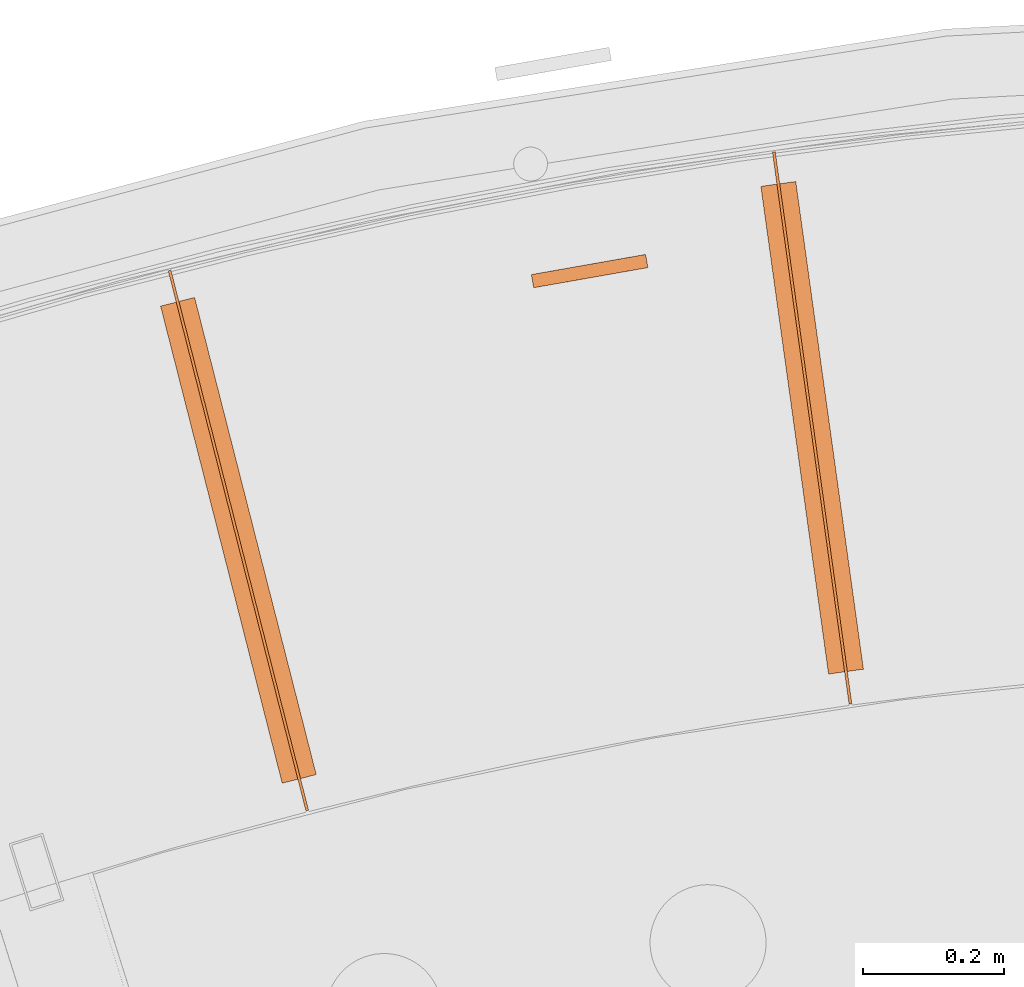
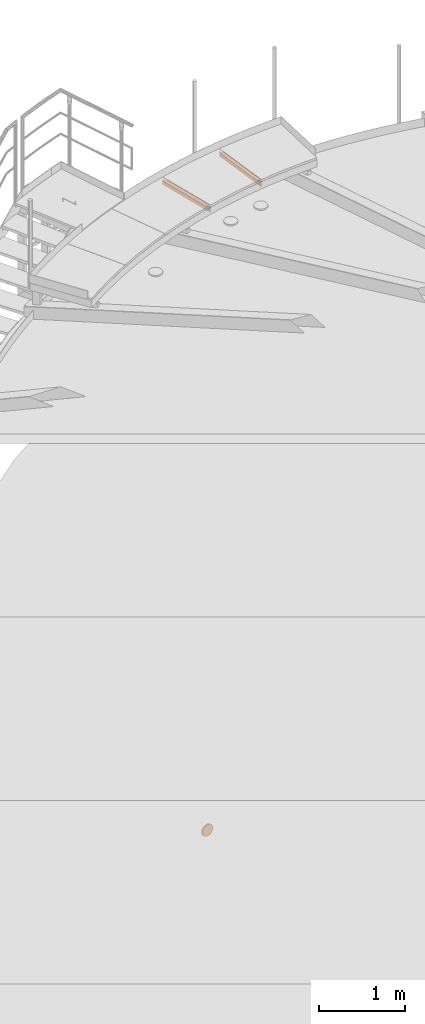
# One storey, part 90 of 126: 5 proxies.
"""IFC2X3 building model written with IfcOpenShell, lengths in millimetres."""

from ifc_helpers import new_model, si_unit, origin, origin_with_axes, place, context, project, spatial, faceted_brep, material, element, save


model = new_model("IFC2X3")

# Units and contexts
context_of_model_1 = context(None, 3, precision=0.1, world=origin())
context_of_model_2 = context(None, 3, precision=0.1, world=origin())
ifc_project = project(units=[si_unit("LENGTHUNIT", "METRE", prefix="MILLI"), si_unit("AREAUNIT", "SQUARE_METRE", prefix="CENTI"), si_unit("VOLUMEUNIT", "CUBIC_METRE", prefix="CENTI"), si_unit("MASSUNIT", "GRAM", prefix="KILO")], contexts=[context_of_model_1, context_of_model_2])

# Site, building, storey
site_placement = place(None, origin_with_axes())
site = spatial("IfcSite", under=ifc_project, at=site_placement, CompositionType="ELEMENT")
building_placement = place(site_placement, origin_with_axes())
building = spatial("IfcBuilding", under=site, at=building_placement, CompositionType="ELEMENT")
storey_placement = place(building_placement, origin_with_axes())
storey = spatial("IfcBuildingStorey", under=building, at=storey_placement, CompositionType="ELEMENT")

# Proxies
ifc_material = material(Name="STAHL")
proxy_1_placement = place(storey_placement, origin_with_axes())
element("IfcBuildingElementProxy", 1, at=proxy_1_placement, inside=storey, material=ifc_material, Name="profile", context=context_of_model_2, shape_type="Brep", body=[
    faceted_brep([(6628.1, 15605.4, 1521.8), (6636.0, 15606.8, 1518.5), (6639.3, 15588.0, 1518.5), (6631.4, 15586.7, 1521.8), (6620.7, 15604.1, 1526.0), (6624.0, 15585.4, 1526.0), (6744.8, 15625.9, 1601.8), (6743.8, 15625.8, 1610.3), (6747.1, 15607.1, 1610.3), (6748.1, 15607.2, 1601.8), (6613.7, 15602.8, 1531.0), (6617.0, 15584.1, 1531.0), (6748.2, 15607.3, 1593.1), (6744.9, 15626.0, 1593.1), (6747.5, 15607.1, 1584.5), (6744.2, 15625.8, 1584.5), (6607.3, 15601.7, 1536.7), (6610.6, 15583.0, 1536.7), (6745.9, 15606.8, 1576.0), (6742.6, 15625.6, 1576.0), (6601.5, 15600.7, 1543.0), (6604.8, 15582.0, 1543.0), (6743.4, 15606.4, 1567.8), (6740.1, 15625.1, 1567.8), (6596.4, 15599.8, 1549.9), (6599.7, 15581.1, 1549.9), (6740.1, 15605.8, 1559.8), (6736.8, 15624.5, 1559.8), (6592.0, 15599.0, 1557.3), (6595.3, 15580.3, 1557.3), (6735.9, 15605.1, 1552.3), (6732.6, 15623.8, 1552.3), (6588.4, 15598.4, 1565.1), (6591.7, 15579.7, 1565.1), (6731.1, 15604.2, 1545.2), (6727.8, 15622.9, 1545.2), (6585.6, 15597.9, 1573.3), (6588.9, 15579.2, 1573.3), (6587.0, 15578.8, 1581.7), (6583.7, 15597.5, 1581.7), (6725.5, 15603.2, 1538.7), (6722.2, 15622.0, 1538.7), (6719.3, 15602.2, 1532.8), (6716.0, 15620.9, 1532.8), (6712.5, 15601.0, 1527.6), (6709.2, 15619.7, 1527.6), (6705.2, 15599.7, 1523.2), (6701.9, 15618.4, 1523.2), (6697.5, 15598.3, 1519.5), (6694.2, 15617.0, 1519.5), (6689.4, 15596.9, 1516.7), (6686.1, 15615.6, 1516.7), (6681.1, 15595.4, 1514.8), (6677.8, 15614.1, 1514.8), (6672.7, 15593.9, 1513.7), (6669.4, 15612.7, 1513.7), (6664.2, 15592.4, 1513.6), (6660.9, 15611.2, 1513.6), (6655.7, 15590.9, 1514.3), (6652.4, 15609.7, 1514.3), (6644.1, 15608.2, 1516.0), (6647.4, 15589.5, 1516.0), (6694.0, 15617.0, 1596.0), (6697.3, 15598.3, 1596.0), (6696.9, 15598.2, 1601.3), (6693.6, 15616.9, 1601.3), (6693.6, 15616.9, 1590.7), (6696.9, 15598.2, 1590.7), (6692.2, 15616.7, 1585.5), (6695.5, 15598.0, 1585.5), (6690.0, 15616.3, 1580.6), (6693.3, 15597.6, 1580.6), (6686.9, 15615.7, 1576.2), (6690.2, 15597.0, 1576.2), (6683.2, 15615.1, 1572.4), (6686.5, 15596.4, 1572.4), (6678.9, 15614.3, 1569.4), (6682.2, 15595.6, 1569.4), (6674.1, 15613.5, 1567.1), (6677.4, 15594.8, 1567.1), (6669.0, 15612.6, 1565.7), (6672.3, 15593.9, 1565.7), (6663.7, 15611.7, 1565.3), (6667.0, 15592.9, 1565.3), (6658.5, 15610.7, 1565.7), (6661.8, 15592.0, 1565.7), (6653.4, 15609.8, 1567.1), (6656.7, 15591.1, 1567.1), (6648.6, 15609.0, 1569.4), (6651.9, 15590.3, 1569.4), (6644.3, 15608.2, 1572.4), (6647.6, 15589.5, 1572.4), (6640.5, 15607.6, 1576.2), (6643.8, 15588.9, 1576.2), (6637.5, 15607.0, 1580.6), (6640.8, 15588.3, 1580.6), (6635.3, 15606.6, 1585.5), (6638.6, 15587.9, 1585.5), (6633.9, 15606.4, 1590.7), (6637.2, 15587.7, 1590.7), (6707.9, 15619.4, 1646.6), (6711.2, 15600.7, 1646.6), (6711.1, 15600.7, 1648.8), (6707.8, 15619.4, 1648.8), (6707.5, 15619.4, 1644.5), (6710.8, 15600.7, 1644.5), (6706.6, 15619.2, 1642.5), (6709.9, 15600.5, 1642.5), (6705.3, 15619.0, 1640.8), (6708.6, 15600.3, 1640.8), (6703.6, 15618.7, 1639.5), (6706.9, 15600.0, 1639.5), (6701.6, 15618.3, 1638.6), (6704.9, 15599.6, 1638.6), (6699.5, 15618.0, 1638.2), (6702.8, 15599.3, 1638.2), (6697.4, 15617.6, 1638.4), (6700.7, 15598.9, 1638.4), (6695.4, 15617.2, 1639.0), (6698.7, 15598.5, 1639.0), (6693.5, 15616.9, 1640.1), (6696.8, 15598.2, 1640.1), (6692.0, 15616.6, 1641.7), (6695.3, 15597.9, 1641.7), (6690.9, 15616.5, 1643.6), (6694.2, 15597.7, 1643.6), (6690.3, 15616.3, 1645.6), (6693.6, 15597.6, 1645.6), (6637.2, 15607.0, 1546.4), (6637.3, 15607.0, 1544.2), (6640.6, 15588.3, 1544.2), (6640.5, 15588.3, 1546.4), (6636.9, 15606.9, 1542.1), (6640.2, 15588.2, 1542.1), (6636.0, 15606.8, 1540.1), (6639.3, 15588.1, 1540.1), (6634.7, 15606.5, 1538.4), (6638.0, 15587.8, 1538.4), (6633.0, 15606.2, 1537.1), (6636.3, 15587.5, 1537.1), (6631.0, 15605.9, 1536.2), (6634.3, 15587.2, 1536.2), (6628.9, 15605.5, 1535.8), (6632.2, 15586.8, 1535.8), (6626.8, 15605.1, 1536.0), (6630.1, 15586.4, 1536.0), (6624.7, 15604.8, 1536.6), (6628.0, 15586.1, 1536.6), (6622.9, 15604.5, 1537.8), (6626.2, 15585.7, 1537.8), (6621.4, 15604.2, 1539.3), (6624.7, 15585.5, 1539.3), (6620.3, 15604.0, 1541.2), (6623.6, 15585.3, 1541.2), (6619.7, 15603.9, 1543.2), (6623.0, 15585.2, 1543.2), (6723.0, 15622.1, 1559.5), (6726.3, 15603.4, 1559.5), (6726.2, 15603.4, 1561.7), (6722.9, 15622.1, 1561.7), (6722.6, 15622.0, 1557.4), (6725.9, 15603.3, 1557.4), (6721.7, 15621.9, 1555.4), (6725.0, 15603.2, 1555.4), (6720.4, 15621.6, 1553.7), (6723.7, 15602.9, 1553.7), (6718.7, 15621.3, 1552.4), (6722.0, 15602.6, 1552.4), (6716.7, 15621.0, 1551.5), (6720.0, 15602.3, 1551.5), (6714.6, 15620.6, 1551.2), (6717.9, 15601.9, 1551.2), (6712.5, 15620.3, 1551.3), (6715.8, 15601.5, 1551.3), (6710.5, 15619.9, 1552.0), (6713.8, 15601.2, 1552.0), (6708.6, 15619.6, 1553.1), (6711.9, 15600.9, 1553.1), (6707.1, 15619.3, 1554.6), (6710.4, 15600.6, 1554.6), (6706.1, 15619.1, 1556.5), (6709.4, 15600.4, 1556.5), (6705.4, 15619.0, 1558.6), (6708.7, 15600.3, 1558.6), (6622.2, 15604.3, 1631.2), (6625.5, 15585.6, 1631.2), (6625.4, 15585.6, 1633.4), (6622.1, 15604.3, 1633.4), (6621.8, 15604.3, 1629.1), (6625.1, 15585.5, 1629.1), (6620.9, 15604.1, 1627.1), (6624.2, 15585.4, 1627.1), (6619.5, 15603.9, 1625.4), (6622.8, 15585.2, 1625.4), (6617.9, 15603.6, 1624.1), (6621.2, 15584.9, 1624.1), (6615.9, 15603.2, 1623.2), (6619.2, 15584.5, 1623.2), (6613.8, 15602.8, 1622.9), (6617.1, 15584.1, 1622.9), (6611.7, 15602.5, 1623.0), (6615.0, 15583.8, 1623.0), (6609.6, 15602.1, 1623.7), (6612.9, 15583.4, 1623.7), (6607.8, 15601.8, 1624.8), (6611.1, 15583.1, 1624.8), (6606.3, 15601.5, 1626.3), (6609.6, 15582.8, 1626.3), (6605.2, 15601.3, 1628.2), (6608.5, 15582.6, 1628.2), (6604.6, 15601.2, 1630.3), (6607.9, 15582.5, 1630.3), (6604.5, 15601.2, 1632.5), (6607.8, 15582.5, 1632.5), (6604.9, 15601.3, 1634.6), (6608.2, 15582.6, 1634.6), (6605.8, 15601.4, 1636.6), (6609.1, 15582.7, 1636.6), (6607.1, 15601.7, 1638.3), (6610.4, 15583.0, 1638.3), (6608.8, 15602.0, 1639.6), (6612.1, 15583.3, 1639.6), (6610.7, 15602.3, 1640.5), (6614.0, 15583.6, 1640.5), (6612.8, 15602.7, 1640.8), (6616.1, 15584.0, 1640.8), (6615.0, 15603.1, 1640.7), (6618.3, 15584.3, 1640.7), (6617.0, 15603.4, 1640.0), (6620.3, 15584.7, 1640.0), (6618.8, 15603.7, 1638.9), (6622.1, 15585.0, 1638.9), (6620.3, 15604.0, 1637.4), (6623.6, 15585.3, 1637.4), (6621.4, 15604.2, 1635.5), (6624.7, 15585.5, 1635.5), (6705.3, 15619.0, 1560.8), (6708.6, 15600.3, 1560.8), (6705.7, 15619.1, 1562.9), (6709.0, 15600.3, 1562.9), (6706.6, 15619.2, 1564.9), (6709.9, 15600.5, 1564.9), (6707.9, 15619.4, 1566.6), (6711.2, 15600.7, 1566.6), (6709.6, 15619.7, 1567.9), (6712.9, 15601.0, 1567.9), (6711.6, 15620.1, 1568.8), (6714.9, 15601.4, 1568.8), (6713.7, 15620.5, 1569.1), (6717.0, 15601.8, 1569.1), (6715.8, 15620.8, 1569.0), (6719.1, 15602.1, 1569.0), (6717.9, 15621.2, 1568.3), (6721.2, 15602.5, 1568.3), (6719.7, 15621.5, 1567.2), (6723.0, 15602.8, 1567.2), (6721.2, 15621.8, 1565.7), (6724.5, 15603.1, 1565.7), (6722.3, 15622.0, 1563.8), (6725.6, 15603.3, 1563.8), (6619.6, 15603.9, 1545.4), (6622.9, 15585.2, 1545.4), (6620.0, 15603.9, 1547.5), (6623.3, 15585.2, 1547.5), (6620.9, 15604.1, 1549.5), (6624.2, 15585.4, 1549.5), (6622.2, 15604.3, 1551.2), (6625.5, 15585.6, 1551.2), (6623.9, 15604.6, 1552.5), (6627.2, 15585.9, 1552.5), (6625.9, 15605.0, 1553.4), (6629.2, 15586.3, 1553.4), (6628.0, 15605.3, 1553.8), (6631.3, 15586.6, 1553.8), (6630.1, 15605.7, 1553.6), (6633.4, 15587.0, 1553.6), (6632.1, 15606.1, 1553.0), (6635.4, 15587.4, 1553.0), (6634.0, 15606.4, 1551.9), (6637.2, 15587.7, 1551.9), (6635.5, 15606.7, 1550.3), (6638.8, 15588.0, 1550.3), (6636.5, 15606.9, 1548.4), (6639.8, 15588.1, 1548.4), (6690.2, 15616.3, 1647.8), (6693.5, 15597.6, 1647.8), (6690.6, 15616.4, 1649.9), (6693.9, 15597.7, 1649.9), (6691.5, 15616.5, 1651.9), (6694.8, 15597.8, 1651.9), (6692.8, 15616.8, 1653.6), (6696.1, 15598.1, 1653.6), (6694.5, 15617.1, 1654.9), (6697.8, 15598.4, 1654.9), (6696.5, 15617.4, 1655.8), (6699.8, 15598.7, 1655.8), (6698.6, 15617.8, 1656.2), (6701.9, 15599.1, 1656.2), (6700.7, 15618.2, 1656.0), (6704.0, 15599.5, 1656.0), (6702.7, 15618.5, 1655.4), (6706.0, 15599.8, 1655.4), (6704.6, 15618.9, 1654.2), (6707.9, 15600.1, 1654.2), (6706.1, 15619.1, 1652.7), (6709.4, 15600.4, 1652.7), (6707.2, 15619.3, 1650.8), (6710.5, 15600.6, 1650.8), (6582.5, 15597.3, 1598.9), (6583.3, 15597.5, 1607.5), (6584.9, 15597.8, 1616.0), (6587.4, 15598.2, 1624.2), (6590.7, 15598.8, 1632.2), (6594.8, 15599.5, 1639.7), (6599.7, 15600.4, 1646.8), (6605.3, 15601.3, 1653.3), (6611.5, 15602.4, 1659.2), (6618.3, 15603.6, 1664.4), (6625.6, 15604.9, 1668.8), (6633.3, 15606.3, 1672.5), (6641.3, 15607.7, 1675.3), (6649.6, 15609.2, 1677.2), (6658.1, 15610.7, 1678.3), (6666.6, 15612.2, 1678.4), (6675.0, 15613.6, 1677.7), (6683.4, 15615.1, 1676.0), (6691.5, 15616.6, 1673.5), (6699.4, 15617.9, 1670.2), (6706.8, 15619.2, 1666.0), (6713.8, 15620.5, 1661.0), (6720.2, 15621.6, 1655.3), (6726.0, 15622.6, 1649.0), (6731.1, 15623.5, 1642.1), (6735.5, 15624.3, 1634.7), (6739.1, 15624.9, 1626.9), (6741.8, 15625.4, 1618.7), (6692.2, 15616.7, 1606.5), (6690.0, 15616.3, 1611.4), (6686.9, 15615.7, 1615.8), (6683.2, 15615.1, 1619.6), (6678.9, 15614.3, 1622.6), (6674.1, 15613.5, 1624.9), (6669.0, 15612.6, 1626.3), (6663.7, 15611.7, 1626.8), (6658.5, 15610.7, 1626.3), (6653.4, 15609.8, 1624.9), (6648.6, 15609.0, 1622.6), (6644.3, 15608.2, 1619.6), (6640.5, 15607.6, 1615.8), (6637.5, 15607.0, 1611.4), (6635.3, 15606.6, 1606.5), (6633.9, 15606.4, 1601.3), (6633.5, 15606.3, 1596.0), (6582.7, 15597.4, 1590.2), (6585.8, 15578.6, 1598.9), (6586.0, 15578.7, 1590.2), (6745.1, 15606.7, 1618.7), (6742.4, 15606.2, 1626.9), (6738.8, 15605.6, 1634.7), (6734.4, 15604.8, 1642.1), (6667.0, 15592.9, 1626.8), (6672.3, 15593.9, 1626.3), (6677.4, 15594.8, 1624.9), (6682.2, 15595.6, 1622.6), (6686.5, 15596.4, 1619.6), (6690.2, 15597.0, 1615.8), (6693.3, 15597.6, 1611.4), (6695.5, 15598.0, 1606.5), (6636.8, 15587.6, 1596.0), (6637.2, 15587.7, 1601.3), (6638.6, 15587.9, 1606.5), (6640.8, 15588.3, 1611.4), (6643.8, 15588.9, 1615.8), (6647.6, 15589.5, 1619.6), (6651.9, 15590.3, 1622.6), (6656.7, 15591.1, 1624.9), (6661.8, 15592.0, 1626.3), (6729.3, 15603.9, 1649.0), (6723.5, 15602.9, 1655.3), (6717.1, 15601.8, 1661.0), (6710.1, 15600.5, 1666.0), (6702.7, 15599.2, 1670.2), (6694.8, 15597.8, 1673.5), (6686.7, 15596.4, 1676.0), (6678.3, 15594.9, 1677.7), (6669.9, 15593.4, 1678.4), (6661.4, 15591.9, 1678.3), (6652.9, 15590.5, 1677.2), (6644.6, 15589.0, 1675.3), (6636.6, 15587.6, 1672.5), (6628.9, 15586.2, 1668.8), (6621.6, 15584.9, 1664.4), (6614.8, 15583.7, 1659.2), (6608.6, 15582.6, 1653.3), (6603.0, 15581.7, 1646.8), (6598.1, 15580.8, 1639.7), (6594.0, 15580.1, 1632.2), (6590.7, 15579.5, 1624.2), (6588.2, 15579.0, 1616.0), (6586.6, 15578.8, 1607.5)], [[[0, 1, 2, 3]], [[4, 0, 3, 5]], [[6, 7, 8, 9]], [[10, 4, 5, 11]], [[6, 9, 12, 13]], [[13, 12, 14, 15]], [[16, 10, 11, 17]], [[15, 14, 18, 19]], [[20, 16, 17, 21]], [[19, 18, 22, 23]], [[24, 20, 21, 25]], [[23, 22, 26, 27]], [[28, 24, 25, 29]], [[27, 26, 30, 31]], [[32, 28, 29, 33]], [[31, 30, 34, 35]], [[36, 32, 33, 37]], [[36, 37, 38, 39]], [[35, 34, 40, 41]], [[41, 40, 42, 43]], [[43, 42, 44, 45]], [[45, 44, 46, 47]], [[47, 46, 48, 49]], [[49, 48, 50, 51]], [[51, 50, 52, 53]], [[53, 52, 54, 55]], [[55, 54, 56, 57]], [[57, 56, 58, 59]], [[60, 59, 58, 61]], [[1, 60, 61, 2]], [[62, 63, 64, 65]], [[66, 67, 63, 62]], [[68, 69, 67, 66]], [[70, 71, 69, 68]], [[72, 73, 71, 70]], [[74, 75, 73, 72]], [[76, 77, 75, 74]], [[78, 79, 77, 76]], [[80, 81, 79, 78]], [[82, 83, 81, 80]], [[84, 85, 83, 82]], [[86, 87, 85, 84]], [[88, 89, 87, 86]], [[90, 91, 89, 88]], [[92, 93, 91, 90]], [[94, 95, 93, 92]], [[96, 97, 95, 94]], [[98, 99, 97, 96]], [[100, 101, 102, 103]], [[104, 105, 101, 100]], [[106, 107, 105, 104]], [[108, 109, 107, 106]], [[110, 111, 109, 108]], [[112, 113, 111, 110]], [[114, 115, 113, 112]], [[116, 117, 115, 114]], [[118, 119, 117, 116]], [[120, 121, 119, 118]], [[122, 123, 121, 120]], [[124, 125, 123, 122]], [[126, 127, 125, 124]], [[128, 129, 130, 131]], [[129, 132, 133, 130]], [[132, 134, 135, 133]], [[134, 136, 137, 135]], [[136, 138, 139, 137]], [[138, 140, 141, 139]], [[140, 142, 143, 141]], [[142, 144, 145, 143]], [[144, 146, 147, 145]], [[146, 148, 149, 147]], [[148, 150, 151, 149]], [[150, 152, 153, 151]], [[152, 154, 155, 153]], [[156, 157, 158, 159]], [[160, 161, 157, 156]], [[162, 163, 161, 160]], [[164, 165, 163, 162]], [[166, 167, 165, 164]], [[168, 169, 167, 166]], [[170, 171, 169, 168]], [[172, 173, 171, 170]], [[174, 175, 173, 172]], [[176, 177, 175, 174]], [[178, 179, 177, 176]], [[180, 181, 179, 178]], [[180, 182, 183, 181]], [[184, 185, 186, 187]], [[188, 189, 185, 184]], [[190, 191, 189, 188]], [[192, 193, 191, 190]], [[194, 195, 193, 192]], [[196, 197, 195, 194]], [[198, 199, 197, 196]], [[200, 201, 199, 198]], [[202, 203, 201, 200]], [[204, 205, 203, 202]], [[206, 207, 205, 204]], [[208, 209, 207, 206]], [[210, 211, 209, 208]], [[210, 212, 213, 211]], [[212, 214, 215, 213]], [[214, 216, 217, 215]], [[216, 218, 219, 217]], [[218, 220, 221, 219]], [[220, 222, 223, 221]], [[222, 224, 225, 223]], [[224, 226, 227, 225]], [[226, 228, 229, 227]], [[228, 230, 231, 229]], [[230, 232, 233, 231]], [[232, 234, 235, 233]], [[234, 187, 186, 235]], [[236, 237, 183, 182]], [[236, 238, 239, 237]], [[238, 240, 241, 239]], [[240, 242, 243, 241]], [[242, 244, 245, 243]], [[244, 246, 247, 245]], [[246, 248, 249, 247]], [[248, 250, 251, 249]], [[250, 252, 253, 251]], [[252, 254, 255, 253]], [[254, 256, 257, 255]], [[256, 258, 259, 257]], [[258, 159, 158, 259]], [[260, 261, 155, 154]], [[260, 262, 263, 261]], [[262, 264, 265, 263]], [[264, 266, 267, 265]], [[266, 268, 269, 267]], [[268, 270, 271, 269]], [[270, 272, 273, 271]], [[272, 274, 275, 273]], [[274, 276, 277, 275]], [[276, 278, 279, 277]], [[278, 280, 281, 279]], [[280, 282, 283, 281]], [[282, 128, 131, 283]], [[126, 284, 285, 127]], [[284, 286, 287, 285]], [[286, 288, 289, 287]], [[288, 290, 291, 289]], [[290, 292, 293, 291]], [[292, 294, 295, 293]], [[294, 296, 297, 295]], [[296, 298, 299, 297]], [[298, 300, 301, 299]], [[300, 302, 303, 301]], [[302, 304, 305, 303]], [[304, 306, 307, 305]], [[306, 103, 102, 307]], [[308, 309, 310, 311, 312, 313, 314, 315, 316, 317, 318, 319, 320, 321, 322, 323, 324, 325, 326, 327, 328, 329, 330, 331, 332, 333, 334, 335, 7, 6, 13, 15, 19, 23, 27, 31, 35, 41, 43, 45, 47, 49, 51, 53, 55, 57, 59, 60, 134, 132, 129, 128, 282, 280, 278, 276, 274, 272, 270, 268, 96, 94, 92, 90, 88, 86, 84, 82, 80, 78, 76, 74, 72, 70, 68, 66, 62, 250, 248, 246, 244, 242, 240, 238, 236, 182, 180, 178, 176, 174, 172, 170, 168, 166, 164, 162, 160, 156, 159, 258, 256, 254, 252, 250, 62, 65, 336, 337, 338, 339, 340, 341, 342, 343, 284, 126, 124, 122, 120, 118, 116, 114, 112, 110, 108, 106, 104, 100, 103, 306, 304, 302, 300, 298, 296, 294, 292, 290, 288, 286, 284, 343, 344, 345, 346, 347, 348, 349, 350, 351, 352, 200, 198, 196, 194, 192, 190, 188, 184, 187, 234, 232, 230, 228, 226, 224, 222, 220, 218, 216, 214, 212, 210, 208, 206, 204, 202, 200, 352, 98, 96, 268, 266, 264, 262, 260, 154, 152, 150, 148, 146, 144, 142, 140, 138, 136, 134, 60, 1, 0, 4, 10, 16, 20, 24, 28, 32, 36, 39, 353]], [[354, 355, 38, 37, 33, 29, 25, 21, 17, 11, 5, 3, 2, 61, 58, 56, 54, 52, 50, 48, 46, 44, 42, 40, 34, 30, 26, 22, 18, 14, 12, 9, 8, 356, 357, 358, 359, 107, 109, 111, 113, 115, 117, 119, 121, 123, 125, 127, 285, 360, 361, 362, 363, 364, 365, 366, 367, 64, 63, 67, 69, 71, 73, 75, 77, 79, 181, 183, 237, 239, 241, 243, 245, 247, 249, 251, 253, 255, 257, 259, 158, 157, 161, 163, 165, 167, 169, 171, 173, 175, 177, 179, 181, 79, 81, 83, 85, 87, 89, 91, 93, 95, 97, 269, 271, 273, 275, 277, 279, 281, 283, 131, 130, 133, 135, 137, 139, 141, 143, 145, 147, 149, 151, 153, 155, 261, 263, 265, 267, 269, 97, 99, 368, 369, 370, 371, 372, 373, 374, 375, 235, 186, 185, 189, 191, 193, 195, 197, 199, 201, 203, 205, 207, 209, 211, 213, 215, 217, 219, 221, 223, 225, 227, 229, 231, 233, 235, 375, 376, 360, 285, 287, 289, 291, 293, 295, 297, 299, 301, 303, 305, 307, 102, 101, 105, 107, 359, 377, 378, 379, 380, 381, 382, 383, 384, 385, 386, 387, 388, 389, 390, 391, 392, 393, 394, 395, 396, 397, 398, 399]], [[98, 352, 368, 99]], [[352, 351, 369, 368]], [[351, 350, 370, 369]], [[350, 349, 371, 370]], [[349, 348, 372, 371]], [[348, 347, 373, 372]], [[347, 346, 374, 373]], [[346, 345, 375, 374]], [[345, 344, 376, 375]], [[344, 343, 360, 376]], [[343, 342, 361, 360]], [[342, 341, 362, 361]], [[341, 340, 363, 362]], [[340, 339, 364, 363]], [[339, 338, 365, 364]], [[338, 337, 366, 365]], [[337, 336, 367, 366]], [[336, 65, 64, 367]], [[326, 382, 381, 327]], [[327, 381, 380, 328]], [[328, 380, 379, 329]], [[353, 39, 38, 355]], [[329, 379, 378, 330]], [[308, 353, 355, 354]], [[330, 378, 377, 331]], [[309, 308, 354, 399]], [[331, 377, 359, 332]], [[310, 309, 399, 398]], [[332, 359, 358, 333]], [[311, 310, 398, 397]], [[333, 358, 357, 334]], [[334, 357, 356, 335]], [[312, 311, 397, 396]], [[335, 356, 8, 7]], [[313, 312, 396, 395]], [[314, 313, 395, 394]], [[315, 314, 394, 393]], [[316, 315, 393, 392]], [[316, 392, 391, 317]], [[317, 391, 390, 318]], [[318, 390, 389, 319]], [[319, 389, 388, 320]], [[320, 388, 387, 321]], [[321, 387, 386, 322]], [[322, 386, 385, 323]], [[323, 385, 384, 324]], [[324, 384, 383, 325]], [[325, 383, 382, 326]]]),
])
proxy_2_placement = place(storey_placement, origin_with_axes())
element("IfcBuildingElementProxy", 2, at=proxy_2_placement, inside=storey, material=ifc_material, Name="profile", context=context_of_model_2, shape_type="Brep", body=[
    faceted_brep([(7038.1, 14987.4, 11051.2), (7038.1, 14987.4, 10981.2), (6929.3, 15771.9, 10981.2), (6929.3, 15771.9, 11051.2), (7034.2, 14986.8, 10981.2), (6925.3, 15771.3, 10981.2), (7034.2, 14986.8, 11051.2), (6925.3, 15771.3, 11051.2)], [[[0, 1, 2, 3]], [[1, 4, 5, 2]], [[4, 6, 7, 5]], [[6, 0, 3, 7]], [[1, 0, 6, 4]], [[7, 3, 2, 5]]]),
])
proxy_3_placement = place(storey_placement, origin_with_axes())
element("IfcBuildingElementProxy", 3, at=proxy_3_placement, inside=storey, material=ifc_material, Name="profile", context=context_of_model_2, shape_type="Brep", body=[
    faceted_brep([(7005.0, 15029.4, 11055.2), (7054.6, 15036.3, 11055.2), (6958.4, 15729.6, 11055.2), (6908.8, 15722.7, 11055.2), (7054.6, 15036.3, 11051.2), (6958.4, 15729.6, 11051.2), (7005.0, 15029.4, 11051.2), (6908.8, 15722.7, 11051.2)], [[[0, 1, 2, 3]], [[1, 4, 5, 2]], [[4, 6, 7, 5]], [[6, 0, 3, 7]], [[1, 0, 6, 4]], [[7, 3, 2, 5]]]),
])
proxy_4_placement = place(storey_placement, origin_with_axes())
element("IfcBuildingElementProxy", 4, at=proxy_4_placement, inside=storey, material=ifc_material, Name="profile", context=context_of_model_2, shape_type="Brep", body=[
    faceted_brep([(6265.8, 14836.1, 11051.2), (6265.8, 14836.1, 10981.2), (6070.2, 15603.5, 10981.2), (6070.2, 15603.5, 11051.2), (6262.0, 14835.1, 10981.2), (6066.3, 15602.6, 10981.2), (6262.0, 14835.1, 11051.2), (6066.3, 15602.6, 11051.2)], [[[0, 1, 2, 3]], [[1, 4, 5, 2]], [[4, 6, 7, 5]], [[6, 0, 3, 7]], [[1, 0, 6, 4]], [[7, 3, 2, 5]]]),
])
proxy_5_placement = place(storey_placement, origin_with_axes())
element("IfcBuildingElementProxy", 5, at=proxy_5_placement, inside=storey, material=ifc_material, Name="profile", context=context_of_model_2, shape_type="Brep", body=[
    faceted_brep([(6228.3, 14874.2, 11055.2), (6276.7, 14886.5, 11055.2), (6103.8, 15564.8, 11055.2), (6055.4, 15552.5, 11055.2), (6276.7, 14886.5, 11051.2), (6103.8, 15564.8, 11051.2), (6228.3, 14874.2, 11051.2), (6055.4, 15552.5, 11051.2)], [[[0, 1, 2, 3]], [[1, 4, 5, 2]], [[4, 6, 7, 5]], [[6, 0, 3, 7]], [[1, 0, 6, 4]], [[7, 3, 2, 5]]]),
])

save(model, "model.ifc")
